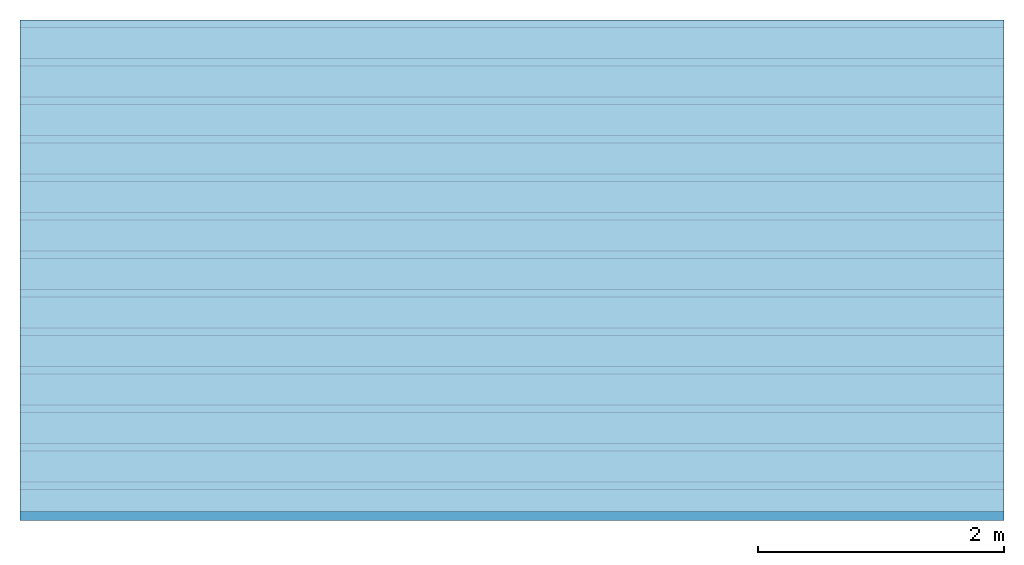
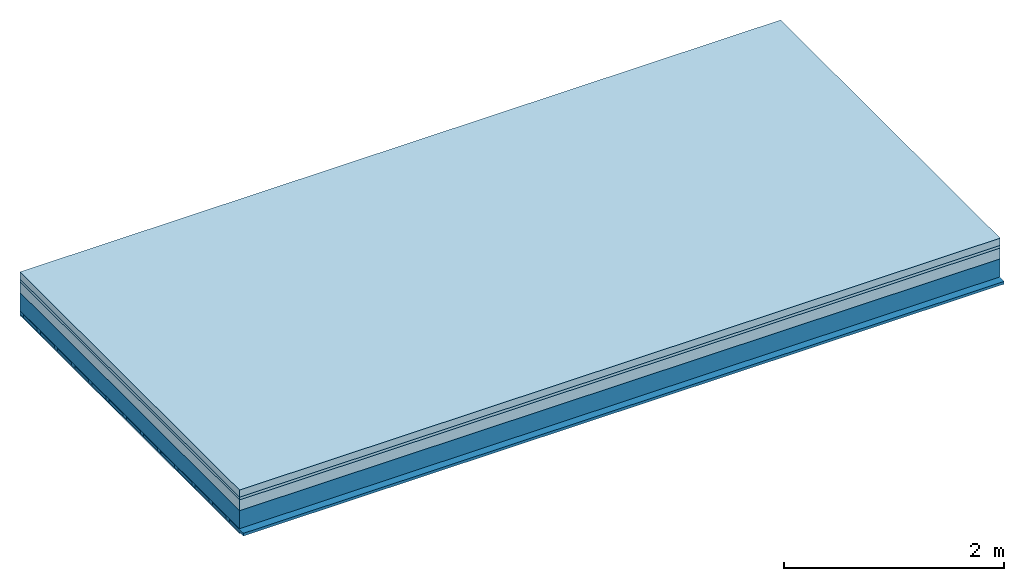
# One storey: 4 plates, 3 members, 1 element without a shape of its own.
"""IFC4 building model written with IfcOpenShell, lengths in metres."""

from ifc_helpers import new_model, si_unit, derived_unit, direction, frame, frame_2d, origin, origin_with_axes, place, context, project, spatial, rectangle, extrude, material, layer, layer_set, type_object, element, aggregate, save


model = new_model("IFC4")

# Units and contexts
plan_context = context("Plan", 3, precision=1e-05, world=origin(), true_north=direction((0.0, 1.0)))
model_context = context("Model", 3, precision=1e-05, world=origin(), true_north=direction((0.0, 1.0)))
ifc_project = project(units=[si_unit("LENGTHUNIT", "METRE"), derived_unit("SOUNDPRESSUREUNIT", [(si_unit("PRESSUREUNIT", "PASCAL", prefix="MICRO"), 0)]), si_unit("ENERGYUNIT", "JOULE", prefix="MEGA"), si_unit("MASSUNIT", "GRAM", prefix="KILO"), derived_unit("THERMALTRANSMITTANCEUNIT", [(si_unit("POWERUNIT", "WATT"), 1), (si_unit("AREAUNIT", "SQUARE_METRE"), -1), (si_unit("THERMODYNAMICTEMPERATUREUNIT", "KELVIN"), -1)]), derived_unit("AREADENSITYUNIT", [(si_unit("MASSUNIT", "GRAM", prefix="KILO"), 1), (si_unit("AREAUNIT", "SQUARE_METRE"), -1)]), derived_unit("USERDEFINED", [(si_unit("ENERGYUNIT", "JOULE", prefix="MEGA"), 1), (si_unit("AREAUNIT", "SQUARE_METRE"), -1)])], contexts=[plan_context, model_context])

# Site, building, storey
site = spatial("IfcSite", under=ifc_project)
building_placement = place(None, origin())
building = spatial("IfcBuilding", under=site, at=building_placement)
storey_placement = place(building_placement, origin())
storey = spatial("IfcBuildingStorey", under=building, at=storey_placement)

# Slab, members, plates
ifc_material_1 = material(Name="Cement screed", Category="04.006")
ifc_layer_1 = layer(ifc_material_1, 0.08, Name="On-material")
ifc_material_2 = material()
ifc_layer_2 = layer(ifc_material_2, 0.03, Name="Impact sound insulation")
ifc_material_3 = material(Category="03.011")
ifc_layer_3 = layer(ifc_material_3, 0.12, Name="on Supporting structure")
ifc_layer_4 = layer(None, 0.2, Name="Supporting structure")
ifc_material_4 = material(Name="of the art")
ifc_layer_5 = layer(ifc_material_4, 0.0, Name="Bond")
ifc_layer_6 = layer(None, 0.04, Name="Battens / profiles")
ifc_material_5 = material(Category="03.007")
ifc_layer_7 = layer(ifc_material_5, 0.015, Name="Ceiling covering 1st layer")
ifc_material_6 = material(Name="Glued joints")
ifc_layer_8 = layer(ifc_material_6, 0.0, Name="Surface / treatment")
ifc_layer_set = layer_set([ifc_layer_1, ifc_layer_2, ifc_layer_3, ifc_layer_4, ifc_layer_5, ifc_layer_6, ifc_layer_7, ifc_layer_8])
slab_type = type_object("IfcSlabType", Name="A1228", PredefinedType="NOTDEFINED", material=ifc_layer_set)
slab_placement = place(None, frame((0.0, 0.0, 0.0), z_axis=(0.0, 0.0, -1.0), x_axis=(1.0, 0.0, 0.0)))
slab = element("IfcSlab", 1, at=slab_placement, inside=storey, type_object=slab_type, material=ifc_layer_set, Name="Slab #1")
ifc_material_7 = material()
member_1_placement = place(slab_placement, origin())
member_1 = element("IfcMember", 2, at=member_1_placement, material=ifc_material_7, Name="Supporting structure", context=plan_context, shape_type="SweptSolid", body=[
    extrude(rectangle(XDim=1.0, YDim=0.2, at=frame_2d((0.5, 0.1), x_axis=(1.0, 0.0))), frame((0.0, 4.0, 0.23), z_axis=(0.0, -1.0, 0.0), x_axis=(1.0, 0.0, 0.0)), (0.0, 0.0, 1.0), 4.0),
    extrude(rectangle(XDim=1.0, YDim=0.2, at=frame_2d((0.5, 0.1), x_axis=(1.0, 0.0))), frame((1.0, 4.0, 0.23), z_axis=(0.0, -1.0, 0.0), x_axis=(1.0, 0.0, 0.0)), (0.0, 0.0, 1.0), 4.0),
    extrude(rectangle(XDim=1.0, YDim=0.2, at=frame_2d((0.5, 0.1), x_axis=(1.0, 0.0))), frame((2.0, 4.0, 0.23), z_axis=(0.0, -1.0, 0.0), x_axis=(1.0, 0.0, 0.0)), (0.0, 0.0, 1.0), 4.0),
    extrude(rectangle(XDim=1.0, YDim=0.2, at=frame_2d((0.5, 0.1), x_axis=(1.0, 0.0))), frame((3.0, 4.0, 0.23), z_axis=(0.0, -1.0, 0.0), x_axis=(1.0, 0.0, 0.0)), (0.0, 0.0, 1.0), 4.0),
    extrude(rectangle(XDim=1.0, YDim=0.2, at=frame_2d((0.5, 0.1), x_axis=(1.0, 0.0))), frame((4.0, 4.0, 0.23), z_axis=(0.0, -1.0, 0.0), x_axis=(1.0, 0.0, 0.0)), (0.0, 0.0, 1.0), 4.0),
    extrude(rectangle(XDim=1.0, YDim=0.2, at=frame_2d((0.5, 0.1), x_axis=(1.0, 0.0))), frame((5.0, 4.0, 0.23), z_axis=(0.0, -1.0, 0.0), x_axis=(1.0, 0.0, 0.0)), (0.0, 0.0, 1.0), 4.0),
    extrude(rectangle(XDim=1.0, YDim=0.2, at=frame_2d((0.5, 0.1), x_axis=(1.0, 0.0))), frame((6.0, 4.0, 0.23), z_axis=(0.0, -1.0, 0.0), x_axis=(1.0, 0.0, 0.0)), (0.0, 0.0, 1.0), 4.0),
    extrude(rectangle(XDim=1.0, YDim=0.2, at=frame_2d((0.5, 0.1), x_axis=(1.0, 0.0))), frame((7.0, 4.0, 0.23), z_axis=(0.0, -1.0, 0.0), x_axis=(1.0, 0.0, 0.0)), (0.0, 0.0, 1.0), 4.0),
])
ifc_material_8 = material()
member_2_placement = place(slab_placement, origin())
member_2 = element("IfcMember", 3, at=member_2_placement, material=ifc_material_8, Name="Battens / profiles", context=plan_context, shape_type="SweptSolid", body=[
    extrude(rectangle(XDim=0.06, YDim=0.04, at=frame_2d((0.03, 0.02), x_axis=(1.0, 0.0))), frame((0.0, 0.0, 0.43), z_axis=(1.0, 0.0, 0.0), x_axis=(0.0, 1.0, 0.0)), (0.0, 0.0, 1.0), 8.0),
    extrude(rectangle(XDim=0.06, YDim=0.04, at=frame_2d((0.03, 0.02), x_axis=(1.0, 0.0))), frame((0.0, 0.313, 0.43), z_axis=(1.0, 0.0, 0.0), x_axis=(0.0, 1.0, 0.0)), (0.0, 0.0, 1.0), 8.0),
    extrude(rectangle(XDim=0.06, YDim=0.04, at=frame_2d((0.03, 0.02), x_axis=(1.0, 0.0))), frame((0.0, 0.626, 0.43), z_axis=(1.0, 0.0, 0.0), x_axis=(0.0, 1.0, 0.0)), (0.0, 0.0, 1.0), 8.0),
    extrude(rectangle(XDim=0.06, YDim=0.04, at=frame_2d((0.03, 0.02), x_axis=(1.0, 0.0))), frame((0.0, 0.939, 0.43), z_axis=(1.0, 0.0, 0.0), x_axis=(0.0, 1.0, 0.0)), (0.0, 0.0, 1.0), 8.0),
    extrude(rectangle(XDim=0.06, YDim=0.04, at=frame_2d((0.03, 0.02), x_axis=(1.0, 0.0))), frame((0.0, 1.252, 0.43), z_axis=(1.0, 0.0, 0.0), x_axis=(0.0, 1.0, 0.0)), (0.0, 0.0, 1.0), 8.0),
    extrude(rectangle(XDim=0.06, YDim=0.04, at=frame_2d((0.03, 0.02), x_axis=(1.0, 0.0))), frame((0.0, 1.565, 0.43), z_axis=(1.0, 0.0, 0.0), x_axis=(0.0, 1.0, 0.0)), (0.0, 0.0, 1.0), 8.0),
    extrude(rectangle(XDim=0.06, YDim=0.04, at=frame_2d((0.03, 0.02), x_axis=(1.0, 0.0))), frame((0.0, 1.878, 0.43), z_axis=(1.0, 0.0, 0.0), x_axis=(0.0, 1.0, 0.0)), (0.0, 0.0, 1.0), 8.0),
    extrude(rectangle(XDim=0.06, YDim=0.04, at=frame_2d((0.03, 0.02), x_axis=(1.0, 0.0))), frame((0.0, 2.191, 0.43), z_axis=(1.0, 0.0, 0.0), x_axis=(0.0, 1.0, 0.0)), (0.0, 0.0, 1.0), 8.0),
    extrude(rectangle(XDim=0.06, YDim=0.04, at=frame_2d((0.03, 0.02), x_axis=(1.0, 0.0))), frame((0.0, 2.504, 0.43), z_axis=(1.0, 0.0, 0.0), x_axis=(0.0, 1.0, 0.0)), (0.0, 0.0, 1.0), 8.0),
    extrude(rectangle(XDim=0.06, YDim=0.04, at=frame_2d((0.03, 0.02), x_axis=(1.0, 0.0))), frame((0.0, 2.817, 0.43), z_axis=(1.0, 0.0, 0.0), x_axis=(0.0, 1.0, 0.0)), (0.0, 0.0, 1.0), 8.0),
    extrude(rectangle(XDim=0.06, YDim=0.04, at=frame_2d((0.03, 0.02), x_axis=(1.0, 0.0))), frame((0.0, 3.13, 0.43), z_axis=(1.0, 0.0, 0.0), x_axis=(0.0, 1.0, 0.0)), (0.0, 0.0, 1.0), 8.0),
    extrude(rectangle(XDim=0.06, YDim=0.04, at=frame_2d((0.03, 0.02), x_axis=(1.0, 0.0))), frame((0.0, 3.443, 0.43), z_axis=(1.0, 0.0, 0.0), x_axis=(0.0, 1.0, 0.0)), (0.0, 0.0, 1.0), 8.0),
    extrude(rectangle(XDim=0.06, YDim=0.04, at=frame_2d((0.03, 0.02), x_axis=(1.0, 0.0))), frame((0.0, 3.756, 0.43), z_axis=(1.0, 0.0, 0.0), x_axis=(0.0, 1.0, 0.0)), (0.0, 0.0, 1.0), 8.0),
])
ifc_material_9 = material()
member_3_placement = place(slab_placement, origin())
member_3 = element("IfcMember", 4, at=member_3_placement, material=ifc_material_9, Name="Cavity", context=plan_context, shape_type="SweptSolid", body=[
    extrude(rectangle(XDim=0.253, YDim=0.03, at=frame_2d((0.1265, 0.015), x_axis=(1.0, 0.0))), frame((0.0, 0.06, 0.44), z_axis=(1.0, 0.0, 0.0), x_axis=(0.0, 1.0, 0.0)), (0.0, 0.0, 1.0), 8.0),
    extrude(rectangle(XDim=0.253, YDim=0.03, at=frame_2d((0.1265, 0.015), x_axis=(1.0, 0.0))), frame((0.0, 0.373, 0.44), z_axis=(1.0, 0.0, 0.0), x_axis=(0.0, 1.0, 0.0)), (0.0, 0.0, 1.0), 8.0),
    extrude(rectangle(XDim=0.253, YDim=0.03, at=frame_2d((0.1265, 0.015), x_axis=(1.0, 0.0))), frame((0.0, 0.686, 0.44), z_axis=(1.0, 0.0, 0.0), x_axis=(0.0, 1.0, 0.0)), (0.0, 0.0, 1.0), 8.0),
    extrude(rectangle(XDim=0.253, YDim=0.03, at=frame_2d((0.1265, 0.015), x_axis=(1.0, 0.0))), frame((0.0, 0.999, 0.44), z_axis=(1.0, 0.0, 0.0), x_axis=(0.0, 1.0, 0.0)), (0.0, 0.0, 1.0), 8.0),
    extrude(rectangle(XDim=0.253, YDim=0.03, at=frame_2d((0.1265, 0.015), x_axis=(1.0, 0.0))), frame((0.0, 1.312, 0.44), z_axis=(1.0, 0.0, 0.0), x_axis=(0.0, 1.0, 0.0)), (0.0, 0.0, 1.0), 8.0),
    extrude(rectangle(XDim=0.253, YDim=0.03, at=frame_2d((0.1265, 0.015), x_axis=(1.0, 0.0))), frame((0.0, 1.625, 0.44), z_axis=(1.0, 0.0, 0.0), x_axis=(0.0, 1.0, 0.0)), (0.0, 0.0, 1.0), 8.0),
    extrude(rectangle(XDim=0.253, YDim=0.03, at=frame_2d((0.1265, 0.015), x_axis=(1.0, 0.0))), frame((0.0, 1.938, 0.44), z_axis=(1.0, 0.0, 0.0), x_axis=(0.0, 1.0, 0.0)), (0.0, 0.0, 1.0), 8.0),
    extrude(rectangle(XDim=0.253, YDim=0.03, at=frame_2d((0.1265, 0.015), x_axis=(1.0, 0.0))), frame((0.0, 2.251, 0.44), z_axis=(1.0, 0.0, 0.0), x_axis=(0.0, 1.0, 0.0)), (0.0, 0.0, 1.0), 8.0),
    extrude(rectangle(XDim=0.253, YDim=0.03, at=frame_2d((0.1265, 0.015), x_axis=(1.0, 0.0))), frame((0.0, 2.564, 0.44), z_axis=(1.0, 0.0, 0.0), x_axis=(0.0, 1.0, 0.0)), (0.0, 0.0, 1.0), 8.0),
    extrude(rectangle(XDim=0.253, YDim=0.03, at=frame_2d((0.1265, 0.015), x_axis=(1.0, 0.0))), frame((0.0, 2.877, 0.44), z_axis=(1.0, 0.0, 0.0), x_axis=(0.0, 1.0, 0.0)), (0.0, 0.0, 1.0), 8.0),
    extrude(rectangle(XDim=0.253, YDim=0.03, at=frame_2d((0.1265, 0.015), x_axis=(1.0, 0.0))), frame((0.0, 3.19, 0.44), z_axis=(1.0, 0.0, 0.0), x_axis=(0.0, 1.0, 0.0)), (0.0, 0.0, 1.0), 8.0),
    extrude(rectangle(XDim=0.253, YDim=0.03, at=frame_2d((0.1265, 0.015), x_axis=(1.0, 0.0))), frame((0.0, 3.503, 0.44), z_axis=(1.0, 0.0, 0.0), x_axis=(0.0, 1.0, 0.0)), (0.0, 0.0, 1.0), 8.0),
    extrude(rectangle(XDim=0.253, YDim=0.03, at=frame_2d((0.1265, 0.015), x_axis=(1.0, 0.0))), frame((0.0, 3.816, 0.44), z_axis=(1.0, 0.0, 0.0), x_axis=(0.0, 1.0, 0.0)), (0.0, 0.0, 1.0), 8.0),
])
plate_1_placement = place(slab_placement, origin())
plate_1 = element("IfcPlate", 5, at=plate_1_placement, material=ifc_material_1, Name="On-material", context=plan_context, shape_type="SweptSolid", body=[
    extrude(rectangle(XDim=8.0, YDim=4.0, at=frame_2d((4.0, 2.0), x_axis=(1.0, 0.0))), origin_with_axes(), (0.0, 0.0, 1.0), 0.08),
])
plate_2_placement = place(slab_placement, origin())
plate_2 = element("IfcPlate", 6, at=plate_2_placement, material=ifc_material_2, Name="Impact sound insulation", context=plan_context, shape_type="SweptSolid", body=[
    extrude(rectangle(XDim=8.0, YDim=4.0, at=frame_2d((4.0, 2.0), x_axis=(1.0, 0.0))), frame((0.0, 0.0, 0.08), z_axis=(0.0, 0.0, 1.0), x_axis=(1.0, 0.0, 0.0)), (0.0, 0.0, 1.0), 0.03),
])
plate_3_placement = place(slab_placement, origin())
plate_3 = element("IfcPlate", 7, at=plate_3_placement, material=ifc_material_3, Name="on Supporting structure", context=plan_context, shape_type="SweptSolid", body=[
    extrude(rectangle(XDim=8.0, YDim=4.0, at=frame_2d((4.0, 2.0), x_axis=(1.0, 0.0))), frame((0.0, 0.0, 0.11), z_axis=(0.0, 0.0, 1.0), x_axis=(1.0, 0.0, 0.0)), (0.0, 0.0, 1.0), 0.12),
])
plate_4_placement = place(slab_placement, origin())
plate_4 = element("IfcPlate", 8, at=plate_4_placement, material=ifc_material_5, Name="Ceiling covering 1st layer", context=plan_context, shape_type="SweptSolid", body=[
    extrude(rectangle(XDim=8.0, YDim=4.0, at=frame_2d((4.0, 2.0), x_axis=(1.0, 0.0))), frame((0.0, 0.0, 0.47), z_axis=(0.0, 0.0, 1.0), x_axis=(1.0, 0.0, 0.0)), (0.0, 0.0, 1.0), 0.015),
])
aggregate(slab, [plate_1, plate_2, plate_3, member_1, member_2, member_3, plate_4])

save(model, "model.ifc")
